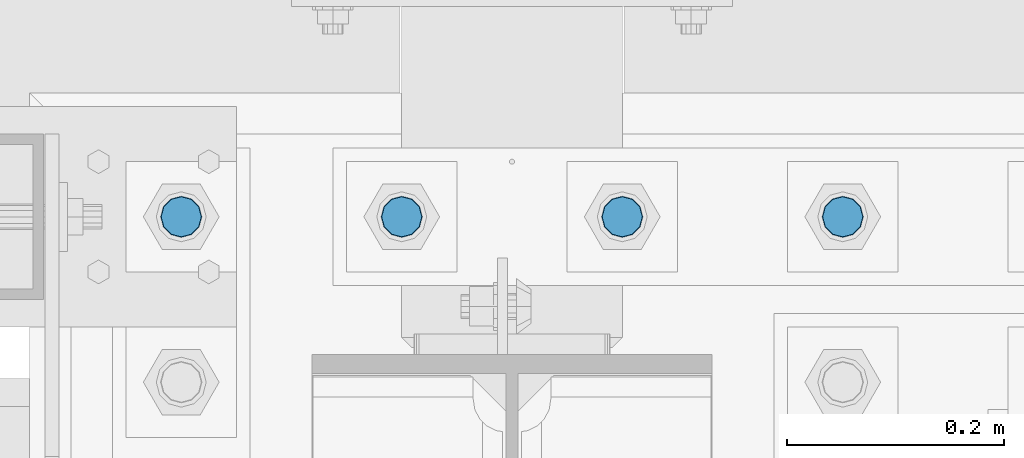
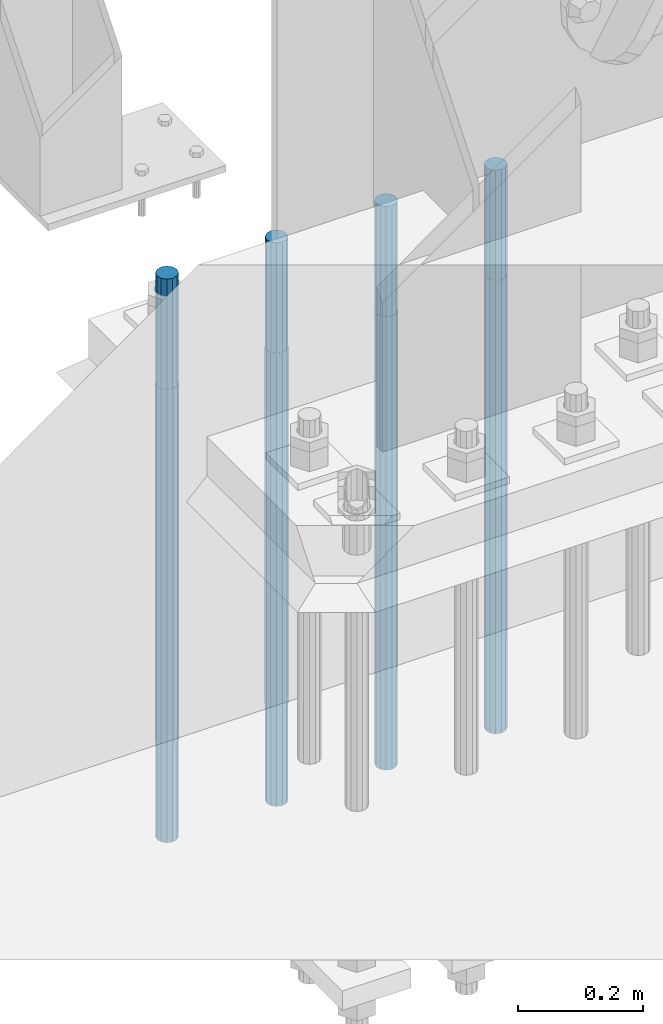
# One storey, part 1379 of 3843: 4 columns, 1 element without a shape of its own.
"""IFC2X3 building model written with IfcOpenShell, lengths in millimetres."""

from ifc_helpers import new_model, si_unit, frame, origin_with_axes, place, context, subcontext, project, spatial, faceted_brep, material, type_object, element, aggregate, save


model = new_model("IFC2X3")

# Units and contexts
model_context = context("Model", 3, precision=1e-05, world=origin_with_axes())
body_context = subcontext(model_context, "Body", "Model", "MODEL_VIEW")
ifc_project = project(units=[si_unit("LENGTHUNIT", "METRE", prefix="MILLI"), si_unit("AREAUNIT", "SQUARE_METRE"), si_unit("VOLUMEUNIT", "CUBIC_METRE"), si_unit("MASSUNIT", "GRAM", prefix="KILO"), si_unit("TIMEUNIT", "SECOND"), si_unit("PLANEANGLEUNIT", "RADIAN"), si_unit("SOLIDANGLEUNIT", "STERADIAN"), si_unit("THERMODYNAMICTEMPERATUREUNIT", "DEGREE_CELSIUS"), si_unit("LUMINOUSINTENSITYUNIT", "LUMEN")], contexts=[model_context])

# Site, building, storey
site_placement = place(None, origin_with_axes())
site = spatial("IfcSite", under=ifc_project, at=site_placement, CompositionType="ELEMENT")
building_placement = place(site_placement, origin_with_axes())
building = spatial("IfcBuilding", under=site, at=building_placement, Name="Undefined", CompositionType="ELEMENT")
storey_placement = place(building_placement, origin_with_axes())
storey = spatial("IfcBuildingStorey", under=building, at=storey_placement, Name="Undefined", CompositionType="ELEMENT", Elevation=0.0)

# Assembly, columns
assembly_placement = place(storey_placement, origin_with_axes())
assembly = element("IfcElementAssembly", 1, at=assembly_placement, inside=storey, Name="TEMPLATE", AssemblyPlace="NOTDEFINED", PredefinedType="RIGID_FRAME")
ifc_material = material(Name="Undefined/F1554-GR.55")
column_type = type_object("IfcColumnType", PredefinedType="NOTDEFINED")
column_1_placement = place(assembly_placement, frame((48691.8, 92519.5, 30022.8), z_axis=(0.0, -1.0, 0.0), x_axis=(0.0, 0.0, -1.0)))
column_1 = element("IfcColumn", 2, at=column_1_placement, type_object=column_type, material=ifc_material, Name="ANCHOR_ROD", context=body_context, shape_type="Brep", body=[
    faceted_brep([(-215.899999999998, -16.0214699700118, 9.25), (-215.899999999998, -9.25, 16.0214699700155), (-215.899999999998, 0.0, 18.5), (-215.899999999998, 9.25, 16.0214699700155), (-215.899999999998, 16.0214699700118, 9.25), (-215.899999999998, 18.5, 0.0), (-215.899999999998, 16.0214699700118, -9.25), (-215.899999999998, 9.25, -16.0214699700155), (-215.899999999998, 0.0, -18.5), (-215.899999999998, -9.25, -16.0214699700155), (-215.899999999998, -16.0214699700118, -9.25), (-215.899999999998, -18.5, 0.0), (0.0, 18.5, 0.0), (0.0, 16.0214699700118, -9.25), (0.0, 9.25, -16.0214699700155), (0.0, 0.0, -18.5), (0.0, -9.25, -16.0214699700155), (0.0, -16.0214699700118, -9.25), (0.0, -18.5, 0.0), (0.0, -16.0214699700118, 9.25), (0.0, -9.25, 16.0214699700155), (0.0, 0.0, 18.5), (0.0, 9.25, 16.0214699700155), (0.0, 16.0214699700118, 9.25), (0.0, -16.4977839420972, 9.52500000000146), (0.0, -9.52500000000146, 16.4977839420972), (0.0, 0.0, 19.0499989999989), (0.0, 9.52500000000146, 16.4977839420972), (0.0, 16.4977839420972, 9.52500000000146), (0.0, 19.0500000000029, 0.0), (0.0, 16.4977839420972, -9.52500000000146), (0.0, 9.52500000000146, -16.4977839420972), (0.0, 0.0, -19.0499989999989), (0.0, -9.52500000000146, -16.4977839420972), (0.0, -16.4977839420972, -9.52500000000146), (0.0, -19.0500000000029, 0.0), (698.5, -19.0499999999993, 0.0), (698.5, -16.4977839420935, 9.52499999999418), (698.5, -9.52500000000146, 16.4977839420899), (698.5, 0.0, 19.0500000000029), (698.5, 9.52500000000146, 16.4977839420899), (698.5, 16.4977839420935, 9.52499999999418), (698.5, 19.0499999999993, 0.0), (698.5, 16.4977839420935, -9.52499999999418), (698.5, 9.52500000000146, -16.4977839420899), (698.5, 0.0, -19.0500000000029), (698.5, -9.52500000000146, -16.4977839420899), (698.5, -16.4977839420935, -9.52499999999418), (698.5, -9.25, 16.0214699700155), (698.5, 0.0, 18.5), (698.5, 9.25, 16.0214699700155), (698.5, 16.0214699700118, 9.25), (698.5, 18.5, 0.0), (698.5, 16.0214699700118, -9.25), (698.5, 9.25, -16.0214699700155), (698.5, 0.0, -18.5), (698.5, -9.25, -16.0214699700155), (698.5, -16.0214699700118, -9.25), (698.5, -18.5, 0.0), (698.5, -16.0214699700118, 9.25), (889.0, -9.25, -16.0214699700155), (889.0, 0.0, -18.5), (889.0, 9.25, -16.0214699700155), (889.0, 16.0214699700118, -9.25), (889.0, 18.5, 0.0), (889.0, 16.0214699700118, 9.25), (889.0, 9.25, 16.0214699700155), (889.0, 0.0, 18.5), (889.0, -9.25, 16.0214699700155), (889.0, -16.0214699700118, 9.25), (889.0, -18.5, 0.0), (889.0, -16.0214699700118, -9.25)], [[[0, 1, 2, 3, 4, 5, 6, 7, 8, 9, 10, 11]], [[6, 5, 12, 13]], [[7, 6, 13, 14]], [[8, 7, 14, 15]], [[9, 8, 15, 16]], [[10, 9, 16, 17]], [[11, 10, 17, 18]], [[0, 11, 18, 19]], [[1, 0, 19, 20]], [[2, 1, 20, 21]], [[3, 2, 21, 22]], [[4, 3, 22, 23]], [[5, 4, 23, 12]], [[24, 25, 26, 27, 28, 29, 30, 31, 32, 33, 34, 35], [22, 21, 20, 19, 18, 17, 16, 15, 14, 13, 12, 23]], [[24, 35, 36, 37]], [[25, 24, 37, 38]], [[26, 25, 38, 39]], [[27, 26, 39, 40]], [[28, 27, 40, 41]], [[29, 28, 41, 42]], [[30, 29, 42, 43]], [[31, 30, 43, 44]], [[32, 31, 44, 45]], [[33, 32, 45, 46]], [[34, 33, 46, 47]], [[35, 34, 47, 36]], [[46, 45, 44, 43, 42, 41, 40, 39, 38, 37, 36, 47], [48, 49, 50, 51, 52, 53, 54, 55, 56, 57, 58, 59]], [[60, 61, 62, 63, 64, 65, 66, 67, 68, 69, 70, 71]], [[68, 67, 49, 48]], [[69, 68, 48, 59]], [[70, 69, 59, 58]], [[71, 70, 58, 57]], [[60, 71, 57, 56]], [[61, 60, 56, 55]], [[62, 61, 55, 54]], [[63, 62, 54, 53]], [[64, 63, 53, 52]], [[65, 64, 52, 51]], [[66, 65, 51, 50]], [[67, 66, 50, 49]]]),
])
column_2_placement = place(assembly_placement, frame((48895.0, 92519.5, 30022.8), z_axis=(0.0, -1.0, 0.0), x_axis=(0.0, 0.0, -1.0)))
column_2 = element("IfcColumn", 3, at=column_2_placement, type_object=column_type, material=ifc_material, Name="ANCHOR_ROD", context=body_context, shape_type="Brep", body=[
    faceted_brep([(-215.899999999998, -16.0214699700118, 9.25), (-215.899999999998, -9.25, 16.0214699700155), (-215.899999999998, 0.0, 18.5), (-215.899999999998, 9.25, 16.0214699700155), (-215.899999999998, 16.0214699700118, 9.25), (-215.899999999998, 18.5, 0.0), (-215.899999999998, 16.0214699700118, -9.25), (-215.899999999998, 9.25, -16.0214699700155), (-215.899999999998, 0.0, -18.5), (-215.899999999998, -9.25, -16.0214699700155), (-215.899999999998, -16.0214699700118, -9.25), (-215.899999999998, -18.5, 0.0), (0.0, 18.5, 0.0), (0.0, 16.0214699700118, -9.25), (0.0, 9.25, -16.0214699700155), (0.0, 0.0, -18.5), (0.0, -9.25, -16.0214699700155), (0.0, -16.0214699700118, -9.25), (0.0, -18.5, 0.0), (0.0, -16.0214699700118, 9.25), (0.0, -9.25, 16.0214699700155), (0.0, 0.0, 18.5), (0.0, 9.25, 16.0214699700155), (0.0, 16.0214699700118, 9.25), (0.0, -16.4977839420972, 9.52500000000146), (0.0, -9.52500000000146, 16.4977839420972), (0.0, 0.0, 19.0499989999989), (0.0, 9.52500000000146, 16.4977839420972), (0.0, 16.4977839420972, 9.52500000000146), (0.0, 19.0500000000029, 0.0), (0.0, 16.4977839420972, -9.52500000000146), (0.0, 9.52500000000146, -16.4977839420972), (0.0, 0.0, -19.0499989999989), (0.0, -9.52500000000146, -16.4977839420972), (0.0, -16.4977839420972, -9.52500000000146), (0.0, -19.0500000000029, 0.0), (698.5, -19.0499999999993, 0.0), (698.5, -16.4977839420935, 9.52499999999418), (698.5, -9.52500000000146, 16.4977839420899), (698.5, 0.0, 19.0500000000029), (698.5, 9.52500000000146, 16.4977839420899), (698.5, 16.4977839420935, 9.52499999999418), (698.5, 19.0499999999993, 0.0), (698.5, 16.4977839420935, -9.52499999999418), (698.5, 9.52500000000146, -16.4977839420899), (698.5, 0.0, -19.0500000000029), (698.5, -9.52500000000146, -16.4977839420899), (698.5, -16.4977839420935, -9.52499999999418), (698.5, -9.25, 16.0214699700155), (698.5, 0.0, 18.5), (698.5, 9.25, 16.0214699700155), (698.5, 16.0214699700118, 9.25), (698.5, 18.5, 0.0), (698.5, 16.0214699700118, -9.25), (698.5, 9.25, -16.0214699700155), (698.5, 0.0, -18.5), (698.5, -9.25, -16.0214699700155), (698.5, -16.0214699700118, -9.25), (698.5, -18.5, 0.0), (698.5, -16.0214699700118, 9.25), (889.0, -9.25, -16.0214699700155), (889.0, 0.0, -18.5), (889.0, 9.25, -16.0214699700155), (889.0, 16.0214699700118, -9.25), (889.0, 18.5, 0.0), (889.0, 16.0214699700118, 9.25), (889.0, 9.25, 16.0214699700155), (889.0, 0.0, 18.5), (889.0, -9.25, 16.0214699700155), (889.0, -16.0214699700118, 9.25), (889.0, -18.5, 0.0), (889.0, -16.0214699700118, -9.25)], [[[0, 1, 2, 3, 4, 5, 6, 7, 8, 9, 10, 11]], [[6, 5, 12, 13]], [[7, 6, 13, 14]], [[8, 7, 14, 15]], [[9, 8, 15, 16]], [[10, 9, 16, 17]], [[11, 10, 17, 18]], [[0, 11, 18, 19]], [[1, 0, 19, 20]], [[2, 1, 20, 21]], [[3, 2, 21, 22]], [[4, 3, 22, 23]], [[5, 4, 23, 12]], [[24, 25, 26, 27, 28, 29, 30, 31, 32, 33, 34, 35], [22, 21, 20, 19, 18, 17, 16, 15, 14, 13, 12, 23]], [[24, 35, 36, 37]], [[25, 24, 37, 38]], [[26, 25, 38, 39]], [[27, 26, 39, 40]], [[28, 27, 40, 41]], [[29, 28, 41, 42]], [[30, 29, 42, 43]], [[31, 30, 43, 44]], [[32, 31, 44, 45]], [[33, 32, 45, 46]], [[34, 33, 46, 47]], [[35, 34, 47, 36]], [[46, 45, 44, 43, 42, 41, 40, 39, 38, 37, 36, 47], [48, 49, 50, 51, 52, 53, 54, 55, 56, 57, 58, 59]], [[60, 61, 62, 63, 64, 65, 66, 67, 68, 69, 70, 71]], [[68, 67, 49, 48]], [[69, 68, 48, 59]], [[70, 69, 59, 58]], [[71, 70, 58, 57]], [[60, 71, 57, 56]], [[61, 60, 56, 55]], [[62, 61, 55, 54]], [[63, 62, 54, 53]], [[64, 63, 53, 52]], [[65, 64, 52, 51]], [[66, 65, 51, 50]], [[67, 66, 50, 49]]]),
])
column_3_placement = place(assembly_placement, frame((49098.2, 92519.5, 30022.8), z_axis=(0.0, -1.0, 0.0), x_axis=(0.0, 0.0, -1.0)))
column_3 = element("IfcColumn", 4, at=column_3_placement, type_object=column_type, material=ifc_material, Name="ANCHOR_ROD", context=body_context, shape_type="Brep", body=[
    faceted_brep([(-215.899999999998, -16.0214699700118, 9.25), (-215.899999999998, -9.25, 16.0214699700155), (-215.899999999998, 0.0, 18.5), (-215.899999999998, 9.25, 16.0214699700155), (-215.899999999998, 16.0214699700118, 9.25), (-215.899999999998, 18.5, 0.0), (-215.899999999998, 16.0214699700118, -9.25), (-215.899999999998, 9.25, -16.0214699700155), (-215.899999999998, 0.0, -18.5), (-215.899999999998, -9.25, -16.0214699700155), (-215.899999999998, -16.0214699700118, -9.25), (-215.899999999998, -18.5, 0.0), (0.0, 18.5, 0.0), (0.0, 16.0214699700118, -9.25), (0.0, 9.25, -16.0214699700155), (0.0, 0.0, -18.5), (0.0, -9.25, -16.0214699700155), (0.0, -16.0214699700118, -9.25), (0.0, -18.5, 0.0), (0.0, -16.0214699700118, 9.25), (0.0, -9.25, 16.0214699700155), (0.0, 0.0, 18.5), (0.0, 9.25, 16.0214699700155), (0.0, 16.0214699700118, 9.25), (0.0, -16.4977839420972, 9.52500000000146), (0.0, -9.52500000000146, 16.4977839420972), (0.0, 0.0, 19.0499989999989), (0.0, 9.52500000000146, 16.4977839420972), (0.0, 16.4977839420972, 9.52500000000146), (0.0, 19.0500000000029, 0.0), (0.0, 16.4977839420972, -9.52500000000146), (0.0, 9.52500000000146, -16.4977839420972), (0.0, 0.0, -19.0499989999989), (0.0, -9.52500000000146, -16.4977839420972), (0.0, -16.4977839420972, -9.52500000000146), (0.0, -19.0500000000029, 0.0), (698.5, -19.0499999999993, 0.0), (698.5, -16.4977839420935, 9.52499999999418), (698.5, -9.52500000000146, 16.4977839420899), (698.5, 0.0, 19.0500000000029), (698.5, 9.52500000000146, 16.4977839420899), (698.5, 16.4977839420935, 9.52499999999418), (698.5, 19.0499999999993, 0.0), (698.5, 16.4977839420935, -9.52499999999418), (698.5, 9.52500000000146, -16.4977839420899), (698.5, 0.0, -19.0500000000029), (698.5, -9.52500000000146, -16.4977839420899), (698.5, -16.4977839420935, -9.52499999999418), (698.5, -9.25, 16.0214699700155), (698.5, 0.0, 18.5), (698.5, 9.25, 16.0214699700155), (698.5, 16.0214699700118, 9.25), (698.5, 18.5, 0.0), (698.5, 16.0214699700118, -9.25), (698.5, 9.25, -16.0214699700155), (698.5, 0.0, -18.5), (698.5, -9.25, -16.0214699700155), (698.5, -16.0214699700118, -9.25), (698.5, -18.5, 0.0), (698.5, -16.0214699700118, 9.25), (889.0, -9.25, -16.0214699700155), (889.0, 0.0, -18.5), (889.0, 9.25, -16.0214699700155), (889.0, 16.0214699700118, -9.25), (889.0, 18.5, 0.0), (889.0, 16.0214699700118, 9.25), (889.0, 9.25, 16.0214699700155), (889.0, 0.0, 18.5), (889.0, -9.25, 16.0214699700155), (889.0, -16.0214699700118, 9.25), (889.0, -18.5, 0.0), (889.0, -16.0214699700118, -9.25)], [[[0, 1, 2, 3, 4, 5, 6, 7, 8, 9, 10, 11]], [[6, 5, 12, 13]], [[7, 6, 13, 14]], [[8, 7, 14, 15]], [[9, 8, 15, 16]], [[10, 9, 16, 17]], [[11, 10, 17, 18]], [[0, 11, 18, 19]], [[1, 0, 19, 20]], [[2, 1, 20, 21]], [[3, 2, 21, 22]], [[4, 3, 22, 23]], [[5, 4, 23, 12]], [[24, 25, 26, 27, 28, 29, 30, 31, 32, 33, 34, 35], [22, 21, 20, 19, 18, 17, 16, 15, 14, 13, 12, 23]], [[24, 35, 36, 37]], [[25, 24, 37, 38]], [[26, 25, 38, 39]], [[27, 26, 39, 40]], [[28, 27, 40, 41]], [[29, 28, 41, 42]], [[30, 29, 42, 43]], [[31, 30, 43, 44]], [[32, 31, 44, 45]], [[33, 32, 45, 46]], [[34, 33, 46, 47]], [[35, 34, 47, 36]], [[46, 45, 44, 43, 42, 41, 40, 39, 38, 37, 36, 47], [48, 49, 50, 51, 52, 53, 54, 55, 56, 57, 58, 59]], [[60, 61, 62, 63, 64, 65, 66, 67, 68, 69, 70, 71]], [[68, 67, 49, 48]], [[69, 68, 48, 59]], [[70, 69, 59, 58]], [[71, 70, 58, 57]], [[60, 71, 57, 56]], [[61, 60, 56, 55]], [[62, 61, 55, 54]], [[63, 62, 54, 53]], [[64, 63, 53, 52]], [[65, 64, 52, 51]], [[66, 65, 51, 50]], [[67, 66, 50, 49]]]),
])
column_4_placement = place(assembly_placement, frame((49301.4, 92519.5, 30022.8), z_axis=(0.0, 1.0, 0.0), x_axis=(0.0, 0.0, -1.0)))
column_4 = element("IfcColumn", 5, at=column_4_placement, type_object=column_type, material=ifc_material, Name="ANCHOR_ROD", context=body_context, shape_type="Brep", body=[
    faceted_brep([(-215.899999999998, -16.0214699700118, 9.25), (-215.899999999998, -9.25, 16.0214699700155), (-215.899999999998, 0.0, 18.5), (-215.899999999998, 9.25, 16.0214699700155), (-215.899999999998, 16.0214699700118, 9.25), (-215.899999999998, 18.5, 0.0), (-215.899999999998, 16.0214699700118, -9.25), (-215.899999999998, 9.25, -16.0214699700155), (-215.899999999998, 0.0, -18.5), (-215.899999999998, -9.25, -16.0214699700155), (-215.899999999998, -16.0214699700118, -9.25), (-215.899999999998, -18.5, 0.0), (0.0, 18.5, 0.0), (0.0, 16.0214699700118, -9.25), (0.0, 9.25, -16.0214699700155), (0.0, 0.0, -18.5), (0.0, -9.25, -16.0214699700155), (0.0, -16.0214699700118, -9.25), (0.0, -18.5, 0.0), (0.0, -16.0214699700118, 9.25), (0.0, -9.25, 16.0214699700155), (0.0, 0.0, 18.5), (0.0, 9.25, 16.0214699700155), (0.0, 16.0214699700118, 9.25), (0.0, -16.4977839420972, 9.52500000000146), (0.0, -9.52500000000146, 16.4977839420972), (0.0, 0.0, 19.0499989999989), (0.0, 9.52500000000146, 16.4977839420972), (0.0, 16.4977839420972, 9.52500000000146), (0.0, 19.0500000000029, 0.0), (0.0, 16.4977839420972, -9.52500000000146), (0.0, 9.52500000000146, -16.4977839420972), (0.0, 0.0, -19.0499989999989), (0.0, -9.52500000000146, -16.4977839420972), (0.0, -16.4977839420972, -9.52500000000146), (0.0, -19.0500000000029, 0.0), (698.5, -19.0499999999993, 0.0), (698.5, -16.4977839420935, 9.52499999999418), (698.5, -9.52500000000146, 16.4977839420899), (698.5, 0.0, 19.0500000000029), (698.5, 9.52500000000146, 16.4977839420899), (698.5, 16.4977839420935, 9.52499999999418), (698.5, 19.0499999999993, 0.0), (698.5, 16.4977839420935, -9.52499999999418), (698.5, 9.52500000000146, -16.4977839420899), (698.5, 0.0, -19.0500000000029), (698.5, -9.52500000000146, -16.4977839420899), (698.5, -16.4977839420935, -9.52499999999418), (698.5, -9.25, 16.0214699700155), (698.5, 0.0, 18.5), (698.5, 9.25, 16.0214699700155), (698.5, 16.0214699700118, 9.25), (698.5, 18.5, 0.0), (698.5, 16.0214699700118, -9.25), (698.5, 9.25, -16.0214699700155), (698.5, 0.0, -18.5), (698.5, -9.25, -16.0214699700155), (698.5, -16.0214699700118, -9.25), (698.5, -18.5, 0.0), (698.5, -16.0214699700118, 9.25), (889.0, -9.25, -16.0214699700155), (889.0, 0.0, -18.5), (889.0, 9.25, -16.0214699700155), (889.0, 16.0214699700118, -9.25), (889.0, 18.5, 0.0), (889.0, 16.0214699700118, 9.25), (889.0, 9.25, 16.0214699700155), (889.0, 0.0, 18.5), (889.0, -9.25, 16.0214699700155), (889.0, -16.0214699700118, 9.25), (889.0, -18.5, 0.0), (889.0, -16.0214699700118, -9.25)], [[[0, 1, 2, 3, 4, 5, 6, 7, 8, 9, 10, 11]], [[6, 5, 12, 13]], [[7, 6, 13, 14]], [[8, 7, 14, 15]], [[9, 8, 15, 16]], [[10, 9, 16, 17]], [[11, 10, 17, 18]], [[0, 11, 18, 19]], [[1, 0, 19, 20]], [[2, 1, 20, 21]], [[3, 2, 21, 22]], [[4, 3, 22, 23]], [[5, 4, 23, 12]], [[24, 25, 26, 27, 28, 29, 30, 31, 32, 33, 34, 35], [22, 21, 20, 19, 18, 17, 16, 15, 14, 13, 12, 23]], [[24, 35, 36, 37]], [[25, 24, 37, 38]], [[26, 25, 38, 39]], [[27, 26, 39, 40]], [[28, 27, 40, 41]], [[29, 28, 41, 42]], [[30, 29, 42, 43]], [[31, 30, 43, 44]], [[32, 31, 44, 45]], [[33, 32, 45, 46]], [[34, 33, 46, 47]], [[35, 34, 47, 36]], [[46, 45, 44, 43, 42, 41, 40, 39, 38, 37, 36, 47], [48, 49, 50, 51, 52, 53, 54, 55, 56, 57, 58, 59]], [[60, 61, 62, 63, 64, 65, 66, 67, 68, 69, 70, 71]], [[68, 67, 49, 48]], [[69, 68, 48, 59]], [[70, 69, 59, 58]], [[71, 70, 58, 57]], [[60, 71, 57, 56]], [[61, 60, 56, 55]], [[62, 61, 55, 54]], [[63, 62, 54, 53]], [[64, 63, 53, 52]], [[65, 64, 52, 51]], [[66, 65, 51, 50]], [[67, 66, 50, 49]]]),
])
aggregate(assembly, [column_1, column_2, column_3, column_4])

save(model, "model.ifc")
